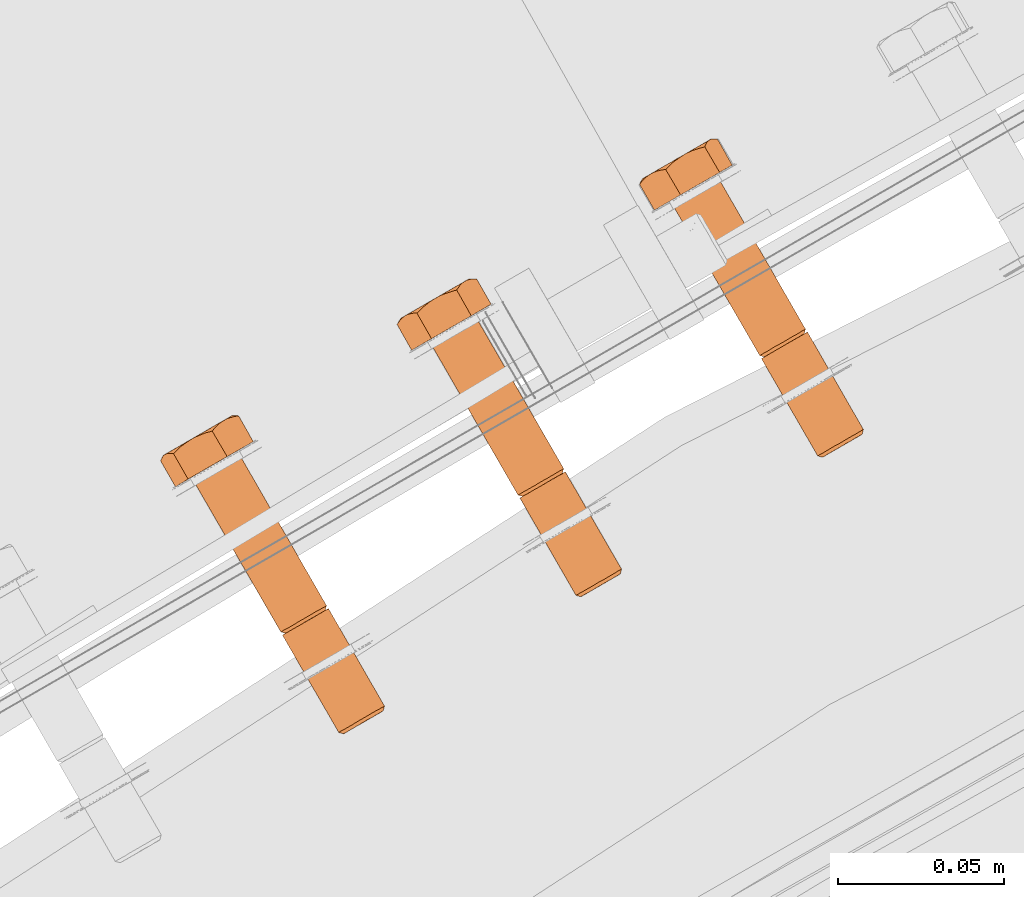
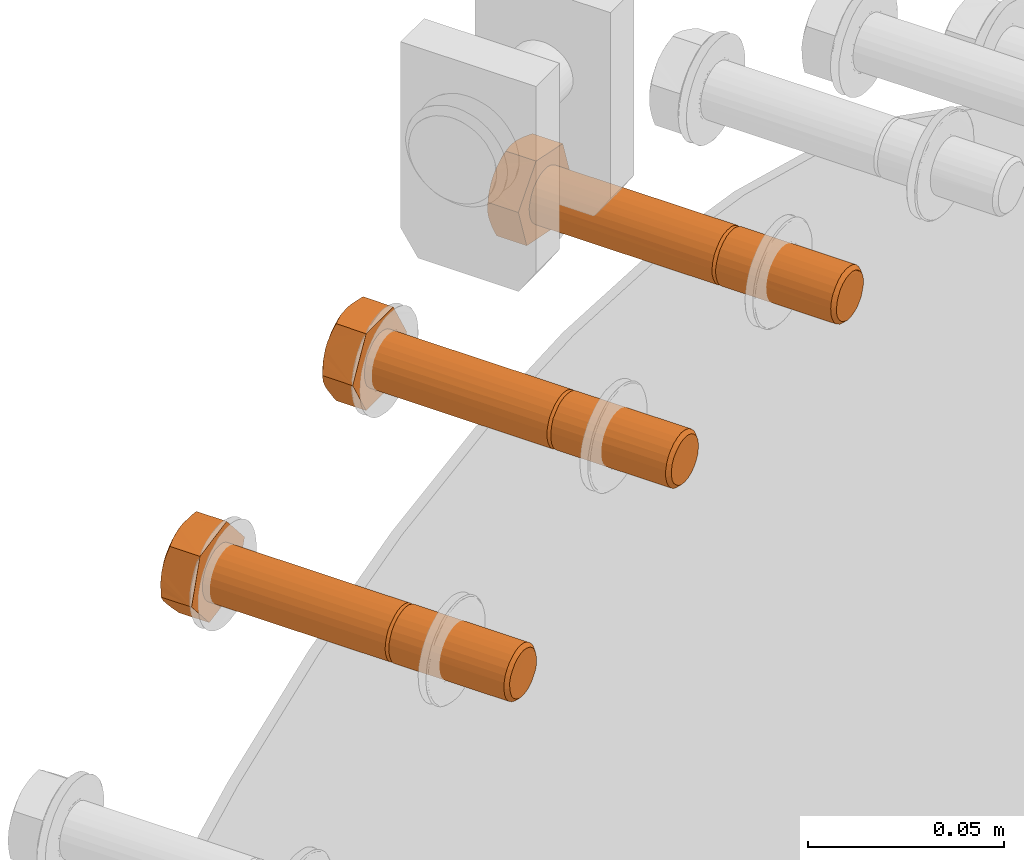
# One storey, part 73 of 126: 3 proxies.
"""IFC2X3 building model written with IfcOpenShell, lengths in millimetres."""

from ifc_helpers import new_model, si_unit, origin, origin_with_axes, place, context, project, spatial, faceted_brep, material, element, save


model = new_model("IFC2X3")

# Units and contexts
context_of_model_1 = context(None, 3, precision=0.1, world=origin())
context_of_model_2 = context(None, 3, precision=0.1, world=origin())
ifc_project = project(units=[si_unit("LENGTHUNIT", "METRE", prefix="MILLI"), si_unit("AREAUNIT", "SQUARE_METRE", prefix="CENTI"), si_unit("VOLUMEUNIT", "CUBIC_METRE", prefix="CENTI"), si_unit("MASSUNIT", "GRAM", prefix="KILO")], contexts=[context_of_model_1, context_of_model_2])

# Site, building, storey
site_placement = place(None, origin_with_axes())
site = spatial("IfcSite", under=ifc_project, at=site_placement, CompositionType="ELEMENT")
building_placement = place(site_placement, origin_with_axes())
building = spatial("IfcBuilding", under=site, at=building_placement, CompositionType="ELEMENT")
storey_placement = place(building_placement, origin_with_axes())
storey = spatial("IfcBuildingStorey", under=building, at=storey_placement, CompositionType="ELEMENT")

# Proxies
ifc_material = material(Name="STAHL")
proxy_1_placement = place(storey_placement, origin_with_axes())
element("IfcBuildingElementProxy", 1, at=proxy_1_placement, inside=storey, material=ifc_material, Name="profile", context=context_of_model_2, shape_type="Brep", body=[
    faceted_brep([(3921.3, 14829.2, 1315.5), (3919.7, 14828.3, 1315.3), (3920.4, 14827.4, 1314.3), (3921.8, 14828.3, 1314.4), (3923.0, 14830.2, 1315.2), (3923.2, 14829.1, 1314.1), (3924.5, 14831.1, 1314.4), (3924.6, 14829.8, 1313.5), (3925.8, 14831.8, 1313.2), (3925.7, 14830.5, 1312.5), (3926.9, 14832.4, 1311.7), (3926.6, 14831.0, 1311.2), (3927.6, 14832.8, 1310.0), (3927.2, 14831.4, 1309.6), (3927.9, 14833.0, 1308.1), (3927.5, 14831.5, 1308.0), (3927.8, 14833.0, 1306.2), (3927.5, 14831.5, 1306.3), (3927.4, 14832.7, 1304.3), (3927.1, 14831.3, 1304.7), (3926.5, 14832.2, 1302.6), (3926.3, 14830.9, 1303.3), (3925.4, 14831.5, 1301.3), (3925.3, 14830.3, 1302.1), (3923.9, 14830.7, 1300.2), (3924.1, 14829.6, 1301.2), (3922.4, 14829.8, 1299.6), (3922.7, 14828.8, 1300.7), (3904.3, 14858.6, 1314.4), (3903.8, 14859.5, 1315.5), (3902.2, 14858.6, 1315.3), (3902.9, 14857.7, 1314.3), (3905.7, 14859.4, 1314.1), (3905.5, 14860.5, 1315.2), (3907.1, 14860.2, 1313.5), (3907.0, 14861.4, 1314.4), (3908.2, 14860.8, 1312.5), (3908.3, 14862.1, 1313.2), (3909.1, 14861.3, 1311.2), (3909.4, 14862.7, 1311.7), (3909.7, 14861.7, 1309.6), (3910.1, 14863.1, 1310.0), (3910.0, 14861.9, 1308.0), (3910.4, 14863.3, 1308.1), (3910.0, 14861.8, 1306.3), (3910.3, 14863.3, 1306.2), (3909.6, 14861.6, 1304.7), (3909.9, 14863.0, 1304.3), (3908.8, 14861.2, 1303.3), (3909.0, 14862.5, 1302.6), (3907.8, 14860.6, 1302.1), (3907.9, 14861.9, 1301.3), (3906.6, 14859.9, 1301.2), (3906.4, 14861.0, 1300.2), (3905.2, 14859.1, 1300.7), (3904.9, 14860.1, 1299.6), (3902.7, 14857.6, 1315.3), (3901.1, 14856.7, 1314.7), (3918.1, 14827.3, 1314.7), (3920.7, 14828.9, 1299.5), (3903.7, 14858.2, 1299.5), (3905.4, 14859.2, 1299.6), (3919.0, 14827.9, 1299.8), (3902.1, 14857.3, 1299.8), (3917.5, 14827.0, 1300.6), (3900.6, 14856.4, 1300.6), (3916.2, 14826.2, 1301.7), (3899.2, 14855.6, 1301.7), (3915.1, 14825.6, 1303.2), (3898.2, 14855.0, 1303.2), (3914.4, 14825.2, 1305.0), (3897.5, 14854.6, 1305.0), (3914.1, 14825.0, 1306.9), (3897.1, 14854.4, 1306.9), (3914.2, 14825.1, 1308.8), (3897.2, 14854.5, 1308.8), (3914.7, 14825.4, 1310.7), (3897.7, 14854.7, 1310.7), (3915.5, 14825.8, 1312.3), (3898.5, 14855.2, 1312.3), (3916.7, 14826.5, 1313.7), (3899.7, 14855.9, 1313.7), (3876.9, 14906.2, 1315.5), (3875.2, 14905.3, 1315.3), (3878.5, 14907.2, 1315.2), (3880.0, 14908.1, 1314.4), (3881.4, 14908.8, 1313.2), (3882.4, 14909.4, 1311.7), (3883.1, 14909.8, 1310.0), (3883.5, 14910.0, 1308.1), (3883.4, 14910.0, 1306.2), (3882.9, 14909.7, 1304.3), (3882.1, 14909.2, 1302.6), (3880.9, 14908.6, 1301.3), (3879.5, 14907.7, 1300.2), (3877.9, 14906.8, 1299.6), (3900.6, 14857.6, 1314.7), (3873.6, 14904.3, 1314.7), (3872.2, 14903.5, 1313.7), (3899.2, 14856.8, 1313.7), (3903.2, 14859.2, 1299.5), (3876.2, 14905.9, 1299.5), (3901.5, 14858.2, 1299.8), (3874.6, 14904.9, 1299.8), (3900.0, 14857.3, 1300.6), (3873.1, 14904.0, 1300.6), (3898.7, 14856.6, 1301.7), (3871.7, 14903.3, 1301.7), (3897.6, 14856.0, 1303.2), (3870.7, 14902.6, 1303.2), (3896.9, 14855.5, 1305.0), (3870.0, 14902.2, 1305.0), (3896.6, 14855.4, 1306.9), (3869.6, 14902.1, 1306.9), (3896.7, 14855.4, 1308.8), (3869.7, 14902.1, 1308.8), (3897.2, 14855.7, 1310.7), (3870.2, 14902.4, 1310.7), (3898.0, 14856.2, 1312.3), (3871.0, 14902.9, 1312.3), (3864.8, 14899.2, 1304.8), (3872.7, 14903.8, 1294.4), (3884.5, 14910.6, 1297.1), (3888.3, 14912.8, 1310.2), (3880.4, 14908.3, 1320.6), (3868.6, 14901.5, 1317.9), (3860.3, 14907.0, 1304.8), (3861.2, 14908.1, 1303.3), (3862.1, 14909.0, 1301.8), (3862.9, 14909.6, 1300.7), (3863.7, 14910.2, 1299.6), (3864.9, 14910.7, 1298.2), (3866.1, 14911.1, 1296.7), (3867.1, 14911.4, 1295.6), (3868.2, 14911.5, 1294.4), (3865.0, 14910.9, 1298.1), (3866.6, 14911.8, 1297.0), (3868.2, 14912.8, 1296.1), (3870.0, 14913.8, 1295.6), (3871.8, 14914.8, 1295.5), (3872.3, 14915.1, 1295.4), (3871.1, 14914.2, 1295.1), (3869.7, 14912.9, 1294.7), (3873.6, 14915.9, 1295.7), (3860.6, 14907.6, 1306.3), (3860.8, 14908.1, 1307.8), (3861.2, 14908.6, 1309.6), (3861.7, 14909.0, 1311.3), (3861.3, 14908.8, 1309.3), (3861.2, 14908.7, 1307.2), (3861.4, 14908.8, 1305.1), (3861.9, 14909.1, 1303.1), (3862.7, 14909.6, 1301.3), (3864.2, 14909.2, 1317.9), (3865.3, 14910.3, 1318.2), (3866.5, 14911.4, 1318.5), (3868.0, 14912.5, 1318.9), (3869.5, 14913.5, 1319.3), (3867.8, 14912.5, 1318.7), (3866.2, 14911.6, 1317.7), (3864.7, 14910.7, 1316.5), (3863.4, 14910.0, 1315.0), (3862.4, 14909.4, 1313.3), (3862.7, 14909.3, 1314.2), (3863.4, 14909.3, 1316.0), (3862.2, 14909.2, 1312.8), (3875.2, 14916.7, 1296.1), (3877.0, 14917.4, 1296.5), (3878.4, 14917.9, 1296.8), (3880.0, 14918.3, 1297.1), (3880.3, 14919.1, 1299.0), (3880.7, 14919.7, 1300.8), (3881.0, 14920.1, 1302.2), (3881.4, 14920.4, 1303.6), (3882.0, 14920.6, 1305.4), (3882.6, 14920.7, 1307.2), (3883.2, 14920.7, 1308.7), (3883.9, 14920.6, 1310.2), (3870.8, 14914.2, 1319.6), (3872.2, 14914.8, 1319.8), (3874.0, 14915.5, 1320.2), (3875.9, 14916.0, 1320.6), (3876.6, 14916.9, 1319.4), (3877.4, 14917.7, 1318.2), (3878.3, 14918.5, 1316.8), (3879.4, 14919.2, 1315.4), (3878.1, 14918.5, 1316.8), (3876.5, 14917.6, 1318.0), (3874.9, 14916.6, 1318.8), (3873.1, 14915.6, 1319.3), (3871.3, 14914.6, 1319.5), (3880.3, 14919.7, 1314.3), (3881.2, 14920.0, 1313.1), (3882.5, 14920.4, 1311.7), (3881.8, 14920.6, 1305.7), (3881.9, 14920.7, 1307.7), (3881.7, 14920.6, 1309.8), (3881.2, 14920.3, 1311.8), (3880.4, 14919.8, 1313.7), (3875.3, 14916.9, 1296.3), (3876.9, 14917.8, 1297.2), (3878.4, 14918.7, 1298.5), (3879.7, 14919.4, 1300.0), (3880.7, 14920.0, 1301.7), (3904.4, 14858.6, 1315.5), (3901.5, 14856.9, 1313.8), (3900.3, 14856.2, 1312.9), (3899.3, 14855.7, 1311.7), (3898.5, 14855.2, 1310.2), (3898.1, 14855.0, 1308.6), (3898.1, 14855.0, 1307.0), (3898.4, 14855.1, 1305.3), (3899.0, 14855.5, 1303.8), (3899.9, 14856.0, 1302.5), (3901.0, 14856.7, 1301.5), (3902.4, 14857.4, 1300.8), (3903.8, 14858.3, 1300.6), (3906.0, 14859.5, 1315.2), (3907.5, 14860.4, 1314.4), (3908.9, 14861.2, 1313.2), (3909.9, 14861.8, 1311.7), (3910.6, 14862.2, 1310.0), (3911.0, 14862.4, 1308.1), (3910.9, 14862.4, 1306.2), (3910.4, 14862.1, 1304.3), (3909.6, 14861.6, 1302.6), (3908.4, 14860.9, 1301.3), (3907.0, 14860.1, 1300.2), (3915.6, 14824.6, 1307.0), (3915.9, 14824.8, 1305.3), (3916.5, 14825.2, 1303.8), (3917.4, 14825.7, 1302.5), (3918.5, 14826.4, 1301.5), (3919.9, 14827.1, 1300.8), (3921.3, 14827.9, 1300.6), (3919.0, 14826.6, 1313.8), (3917.8, 14825.9, 1312.9), (3916.8, 14825.3, 1311.7), (3916.0, 14824.9, 1310.2), (3915.6, 14824.7, 1308.6)], [[[0, 1, 2, 3]], [[4, 0, 3, 5]], [[6, 4, 5, 7]], [[8, 6, 7, 9]], [[10, 8, 9, 11]], [[12, 10, 11, 13]], [[14, 12, 13, 15]], [[16, 14, 15, 17]], [[18, 16, 17, 19]], [[20, 18, 19, 21]], [[22, 20, 21, 23]], [[24, 22, 23, 25]], [[26, 24, 25, 27]], [[28, 29, 30, 31]], [[32, 33, 29, 28]], [[34, 35, 33, 32]], [[36, 37, 35, 34]], [[38, 39, 37, 36]], [[40, 41, 39, 38]], [[42, 43, 41, 40]], [[44, 45, 43, 42]], [[46, 47, 45, 44]], [[48, 49, 47, 46]], [[50, 51, 49, 48]], [[52, 53, 51, 50]], [[54, 55, 53, 52]], [[1, 56, 57, 58]], [[59, 60, 61, 26]], [[62, 63, 60, 59]], [[64, 65, 63, 62]], [[66, 67, 65, 64]], [[68, 69, 67, 66]], [[70, 71, 69, 68]], [[72, 73, 71, 70]], [[74, 75, 73, 72]], [[76, 77, 75, 74]], [[78, 79, 77, 76]], [[80, 81, 79, 78]], [[58, 57, 81, 80]], [[30, 29, 82, 83]], [[29, 33, 84, 82]], [[33, 35, 85, 84]], [[35, 37, 86, 85]], [[37, 39, 87, 86]], [[39, 41, 88, 87]], [[41, 43, 89, 88]], [[43, 45, 90, 89]], [[45, 47, 91, 90]], [[47, 49, 92, 91]], [[49, 51, 93, 92]], [[51, 53, 94, 93]], [[53, 55, 95, 94]], [[96, 97, 98, 99]], [[30, 83, 97, 96]], [[55, 100, 101, 95]], [[102, 103, 101, 100]], [[104, 105, 103, 102]], [[106, 107, 105, 104]], [[108, 109, 107, 106]], [[110, 111, 109, 108]], [[112, 113, 111, 110]], [[114, 115, 113, 112]], [[116, 117, 115, 114]], [[118, 119, 117, 116]], [[99, 98, 119, 118]], [[120, 121, 122, 123, 124, 86, 87, 88, 89, 90, 91, 92, 93, 94, 95, 101, 103, 105, 107, 109, 111, 113, 115, 117, 119, 98, 97, 83, 82, 84, 85, 86, 124, 125]], [[120, 126, 127, 128, 129, 130, 131, 132, 133, 134, 121]], [[130, 135, 136, 137, 138, 139, 140, 141, 142, 134, 133, 132, 131]], [[143, 140, 139]], [[126, 144, 145, 146, 147, 148, 149, 150, 151, 152, 129, 128, 127]], [[130, 129, 152]], [[153, 154, 155, 156, 157, 158, 159, 160, 161, 162, 163, 164]], [[165, 163, 162]], [[147, 165, 162]], [[121, 134, 142, 141, 140, 143, 166, 167, 168, 169, 122]], [[122, 169, 170, 171, 172, 173, 174, 175, 176, 177, 123]], [[178, 179, 180, 181, 182, 183, 184, 185, 186, 187, 188, 189, 190]], [[157, 178, 190]], [[191, 192, 193, 177, 176, 175, 174, 173, 194, 195, 196, 197, 198]], [[185, 191, 198]], [[143, 199, 200, 201, 202, 203, 171, 170, 169, 168, 167, 166]], [[172, 171, 203]], [[173, 172, 203]], [[124, 123, 177, 193, 192, 191, 185, 184, 183, 182, 181]], [[125, 124, 181, 180, 179, 178, 157, 156, 155, 154, 153]], [[120, 125, 153, 164, 163, 165, 147, 146, 145, 144, 126]], [[149, 148, 147, 162, 161, 160, 159, 158, 157, 190, 189, 188, 187, 186, 185, 198, 197, 196, 195, 194, 173, 203, 202, 201, 200, 199, 143, 139, 138, 137, 136, 135, 130, 152, 151, 150]], [[73, 75, 77, 79, 81, 57, 56, 204, 28, 31, 205, 206, 207, 208, 209, 210, 211, 212, 213, 214, 215, 216, 54, 52, 50, 48, 46, 44, 42, 40, 38, 36, 34, 32, 28, 204, 217, 218, 219, 220, 221, 222, 223, 224, 225, 226, 227, 61, 60, 63, 65, 67, 69, 71]], [[100, 55, 54, 216]], [[102, 100, 216, 215]], [[104, 102, 215, 214]], [[106, 104, 214, 213]], [[108, 106, 213, 212]], [[110, 108, 212, 211]], [[112, 110, 211, 210]], [[114, 112, 210, 209]], [[116, 114, 209, 208]], [[118, 116, 208, 207]], [[99, 118, 207, 206]], [[96, 99, 206, 205]], [[31, 30, 96, 205]], [[0, 204, 56, 1]], [[0, 4, 217, 204]], [[4, 6, 218, 217]], [[6, 8, 219, 218]], [[8, 10, 220, 219]], [[10, 12, 221, 220]], [[12, 14, 222, 221]], [[14, 16, 223, 222]], [[16, 18, 224, 223]], [[18, 20, 225, 224]], [[20, 22, 226, 225]], [[22, 24, 227, 226]], [[24, 26, 61, 227]], [[228, 229, 230, 231, 232, 233, 234, 27, 25, 23, 21, 19, 17, 15, 13, 11, 9, 7, 5, 3, 2, 235, 236, 237, 238, 239]], [[234, 59, 26, 27]], [[233, 62, 59, 234]], [[232, 64, 62, 233]], [[231, 66, 64, 232]], [[230, 68, 66, 231]], [[229, 70, 68, 230]], [[228, 72, 70, 229]], [[239, 74, 72, 228]], [[238, 76, 74, 239]], [[237, 78, 76, 238]], [[236, 80, 78, 237]], [[235, 58, 80, 236]], [[2, 1, 58, 235]]]),
])
proxy_2_placement = place(storey_placement, origin_with_axes())
element("IfcBuildingElementProxy", 2, at=proxy_2_placement, inside=storey, material=ifc_material, Name="profile", context=context_of_model_2, shape_type="Brep", body=[
    faceted_brep([(3994.6, 14870.3, 1330.6), (3994.3, 14871.3, 1331.7), (3992.6, 14870.4, 1331.9), (3993.1, 14869.4, 1330.8), (3995.9, 14871.0, 1330.1), (3995.8, 14872.2, 1331.0), (3997.1, 14871.7, 1329.1), (3997.2, 14873.0, 1329.9), (3998.1, 14872.3, 1327.9), (3998.3, 14873.7, 1328.5), (3998.8, 14872.7, 1326.4), (3999.1, 14874.1, 1326.8), (3999.1, 14872.9, 1324.8), (3999.5, 14874.3, 1324.9), (3999.1, 14872.9, 1323.1), (3999.5, 14874.3, 1323.0), (3998.8, 14872.7, 1321.5), (3999.1, 14874.1, 1321.1), (3998.1, 14872.3, 1320.0), (3998.3, 14873.7, 1319.4), (3997.1, 14871.7, 1318.8), (3997.2, 14873.0, 1317.9), (3995.9, 14871.0, 1317.8), (3995.8, 14872.2, 1316.8), (3994.6, 14870.3, 1317.2), (3994.3, 14871.3, 1316.2), (3993.1, 14869.4, 1317.0), (3992.6, 14870.4, 1315.9), (3977.1, 14900.6, 1330.6), (3976.8, 14901.6, 1331.7), (3975.1, 14900.7, 1331.9), (3975.6, 14899.7, 1330.8), (3978.4, 14901.4, 1330.1), (3978.3, 14902.5, 1331.0), (3979.6, 14902.0, 1329.1), (3979.7, 14903.3, 1329.9), (3980.6, 14902.6, 1327.9), (3980.8, 14904.0, 1328.5), (3981.3, 14903.0, 1326.4), (3981.6, 14904.4, 1326.8), (3981.6, 14903.2, 1324.8), (3982.0, 14904.7, 1324.9), (3981.6, 14903.2, 1323.1), (3982.0, 14904.7, 1323.0), (3981.3, 14903.0, 1321.5), (3981.6, 14904.4, 1321.1), (3980.6, 14902.6, 1320.0), (3980.8, 14904.0, 1319.4), (3979.6, 14902.0, 1318.8), (3979.7, 14903.3, 1317.9), (3978.4, 14901.4, 1317.8), (3978.3, 14902.5, 1316.8), (3977.1, 14900.6, 1317.2), (3976.8, 14901.6, 1316.2), (3975.6, 14899.7, 1317.0), (3975.1, 14900.7, 1315.9), (3975.6, 14899.7, 1331.9), (3974.0, 14898.8, 1331.7), (3991.0, 14869.4, 1331.7), (3991.0, 14869.4, 1316.2), (3974.0, 14898.8, 1316.2), (3975.6, 14899.7, 1315.9), (3989.4, 14868.5, 1316.8), (3972.4, 14897.9, 1316.8), (3988.0, 14867.7, 1317.9), (3971.1, 14897.1, 1317.9), (3986.9, 14867.1, 1319.4), (3969.9, 14896.5, 1319.4), (3986.1, 14866.6, 1321.1), (3969.2, 14896.0, 1321.1), (3985.7, 14866.4, 1323.0), (3968.8, 14895.8, 1323.0), (3985.7, 14866.4, 1324.9), (3968.8, 14895.8, 1324.9), (3986.1, 14866.6, 1326.8), (3969.2, 14896.0, 1326.8), (3986.9, 14867.1, 1328.5), (3969.9, 14896.5, 1328.5), (3988.0, 14867.7, 1329.9), (3971.1, 14897.1, 1329.9), (3989.4, 14868.5, 1331.0), (3972.4, 14897.9, 1331.0), (3949.8, 14948.3, 1331.7), (3948.1, 14947.4, 1331.9), (3951.4, 14949.2, 1331.0), (3952.7, 14950.0, 1329.9), (3953.9, 14950.7, 1328.5), (3954.6, 14951.1, 1326.8), (3955.0, 14951.3, 1324.9), (3955.0, 14951.3, 1323.0), (3954.6, 14951.1, 1321.1), (3953.9, 14950.7, 1319.4), (3952.7, 14950.0, 1317.9), (3951.4, 14949.2, 1316.8), (3949.8, 14948.3, 1316.2), (3948.1, 14947.4, 1315.9), (3973.5, 14899.7, 1316.2), (3946.5, 14946.4, 1316.2), (3971.9, 14898.8, 1316.8), (3944.9, 14945.5, 1316.8), (3970.5, 14898.0, 1317.9), (3943.6, 14944.7, 1317.9), (3969.4, 14897.4, 1319.4), (3942.4, 14944.1, 1319.4), (3968.6, 14896.9, 1321.1), (3941.7, 14943.6, 1321.1), (3968.2, 14896.7, 1323.0), (3941.3, 14943.4, 1323.0), (3968.2, 14896.7, 1324.9), (3941.3, 14943.4, 1324.9), (3968.6, 14896.9, 1326.8), (3941.7, 14943.6, 1326.8), (3969.4, 14897.4, 1328.5), (3942.4, 14944.1, 1328.5), (3970.5, 14898.0, 1329.9), (3943.6, 14944.7, 1329.9), (3971.9, 14898.8, 1331.0), (3944.9, 14945.5, 1331.0), (3973.5, 14899.7, 1331.7), (3946.5, 14946.4, 1331.7), (3936.1, 14940.4, 1323.9), (3942.1, 14943.9, 1311.9), (3954.1, 14950.8, 1311.9), (3960.1, 14954.3, 1323.9), (3954.1, 14950.8, 1335.9), (3942.1, 14943.9, 1335.9), (3931.7, 14948.2, 1323.9), (3932.3, 14949.1, 1322.2), (3932.9, 14949.9, 1320.5), (3933.5, 14950.4, 1319.2), (3934.1, 14950.8, 1317.9), (3935.0, 14951.2, 1316.3), (3936.0, 14951.5, 1314.7), (3936.8, 14951.6, 1313.3), (3937.7, 14951.6, 1311.9), (3935.2, 14951.4, 1316.2), (3936.5, 14952.2, 1314.7), (3938.0, 14953.0, 1313.5), (3939.6, 14954.0, 1312.7), (3941.3, 14955.0, 1312.1), (3941.9, 14955.2, 1311.9), (3940.6, 14954.3, 1311.9), (3939.1, 14953.1, 1311.9), (3943.1, 14956.0, 1311.9), (3932.2, 14948.9, 1325.3), (3932.7, 14949.6, 1326.7), (3933.4, 14950.3, 1328.3), (3934.1, 14950.8, 1329.9), (3933.4, 14950.4, 1328.0), (3932.9, 14950.1, 1326.0), (3932.8, 14950.0, 1323.9), (3932.9, 14950.1, 1321.8), (3933.4, 14950.4, 1319.8), (3934.8, 14951.2, 1331.2), (3935.6, 14951.4, 1332.5), (3936.6, 14951.6, 1334.2), (3937.7, 14951.6, 1335.9), (3938.9, 14952.8, 1335.9), (3940.0, 14953.8, 1335.9), (3941.5, 14955.0, 1335.9), (3943.1, 14956.0, 1335.9), (3941.3, 14955.0, 1335.7), (3939.6, 14954.0, 1335.2), (3938.0, 14953.0, 1334.3), (3936.5, 14952.2, 1333.1), (3935.2, 14951.4, 1331.6), (3944.8, 14956.9, 1311.9), (3946.6, 14957.6, 1311.9), (3948.1, 14958.1, 1311.9), (3949.7, 14958.6, 1311.9), (3950.3, 14959.5, 1313.7), (3950.9, 14960.3, 1315.3), (3951.5, 14960.8, 1316.6), (3952.1, 14961.2, 1317.9), (3953.0, 14961.6, 1319.6), (3954.0, 14961.9, 1321.2), (3954.8, 14962.0, 1322.5), (3955.7, 14962.0, 1323.9), (3945.0, 14957.1, 1335.7), (3945.9, 14957.4, 1335.9), (3947.7, 14958.0, 1335.9), (3949.7, 14958.6, 1335.9), (3950.2, 14959.3, 1334.5), (3950.7, 14960.0, 1333.2), (3951.4, 14960.7, 1331.6), (3952.1, 14961.2, 1329.9), (3951.1, 14960.6, 1331.6), (3949.8, 14959.9, 1333.1), (3948.3, 14959.0, 1334.3), (3946.7, 14958.1, 1335.2), (3944.5, 14956.8, 1335.9), (3952.9, 14961.7, 1319.8), (3953.4, 14961.9, 1321.8), (3953.5, 14962.0, 1323.9), (3953.4, 14961.9, 1326.0), (3952.9, 14961.7, 1328.0), (3952.8, 14961.6, 1328.6), (3953.6, 14961.8, 1327.3), (3954.6, 14962.0, 1325.7), (3945.0, 14957.1, 1312.1), (3946.7, 14958.1, 1312.7), (3948.3, 14959.0, 1313.5), (3949.8, 14959.9, 1314.7), (3951.1, 14960.6, 1316.2), (3977.3, 14900.7, 1331.7), (3978.9, 14901.6, 1331.0), (3980.2, 14902.4, 1329.9), (3981.4, 14903.0, 1328.5), (3982.1, 14903.5, 1326.8), (3982.5, 14903.7, 1324.9), (3982.5, 14903.7, 1323.0), (3982.1, 14903.5, 1321.1), (3981.4, 14903.0, 1319.4), (3980.2, 14902.4, 1317.9), (3978.9, 14901.6, 1316.8), (3977.3, 14900.7, 1316.2), (3969.7, 14896.3, 1323.1), (3970.0, 14896.5, 1321.5), (3970.7, 14896.9, 1320.0), (3971.7, 14897.5, 1318.8), (3972.9, 14898.1, 1317.8), (3974.2, 14898.9, 1317.2), (3974.2, 14898.9, 1330.6), (3972.9, 14898.1, 1330.1), (3971.7, 14897.5, 1329.1), (3970.7, 14896.9, 1327.9), (3970.0, 14896.5, 1326.4), (3969.7, 14896.3, 1324.8), (3987.2, 14866.0, 1324.8), (3987.2, 14866.0, 1323.1), (3987.5, 14866.2, 1321.5), (3988.2, 14866.6, 1320.0), (3989.2, 14867.1, 1318.8), (3990.4, 14867.8, 1317.8), (3991.7, 14868.6, 1317.2), (3991.7, 14868.6, 1330.6), (3990.4, 14867.8, 1330.1), (3989.2, 14867.1, 1329.1), (3988.2, 14866.6, 1327.9), (3987.5, 14866.2, 1326.4)], [[[0, 1, 2, 3]], [[4, 5, 1, 0]], [[6, 7, 5, 4]], [[8, 9, 7, 6]], [[10, 11, 9, 8]], [[12, 13, 11, 10]], [[14, 15, 13, 12]], [[16, 17, 15, 14]], [[18, 19, 17, 16]], [[20, 21, 19, 18]], [[22, 23, 21, 20]], [[24, 25, 23, 22]], [[26, 27, 25, 24]], [[28, 29, 30, 31]], [[32, 33, 29, 28]], [[34, 35, 33, 32]], [[36, 37, 35, 34]], [[38, 39, 37, 36]], [[40, 41, 39, 38]], [[42, 43, 41, 40]], [[44, 45, 43, 42]], [[46, 47, 45, 44]], [[48, 49, 47, 46]], [[50, 51, 49, 48]], [[52, 53, 51, 50]], [[54, 55, 53, 52]], [[2, 56, 57, 58]], [[59, 60, 61, 27]], [[62, 63, 60, 59]], [[64, 65, 63, 62]], [[66, 67, 65, 64]], [[68, 69, 67, 66]], [[70, 71, 69, 68]], [[72, 73, 71, 70]], [[74, 75, 73, 72]], [[76, 77, 75, 74]], [[78, 79, 77, 76]], [[80, 81, 79, 78]], [[58, 57, 81, 80]], [[30, 29, 82, 83]], [[29, 33, 84, 82]], [[33, 35, 85, 84]], [[35, 37, 86, 85]], [[37, 39, 87, 86]], [[39, 41, 88, 87]], [[41, 43, 89, 88]], [[43, 45, 90, 89]], [[45, 47, 91, 90]], [[47, 49, 92, 91]], [[49, 51, 93, 92]], [[51, 53, 94, 93]], [[53, 55, 95, 94]], [[96, 97, 95, 55]], [[96, 98, 99, 97]], [[98, 100, 101, 99]], [[100, 102, 103, 101]], [[102, 104, 105, 103]], [[104, 106, 107, 105]], [[106, 108, 109, 107]], [[108, 110, 111, 109]], [[110, 112, 113, 111]], [[112, 114, 115, 113]], [[114, 116, 117, 115]], [[116, 118, 119, 117]], [[118, 30, 83, 119]], [[120, 121, 122, 123, 124, 86, 87, 88, 89, 90, 91, 92, 93, 94, 95, 97, 99, 101, 103, 105, 107, 109, 111, 113, 115, 117, 119, 83, 82, 84, 85, 86, 124, 125]], [[120, 126, 127, 128, 129, 130, 131, 132, 133, 134, 121]], [[130, 135, 136, 137, 138, 139, 140, 141, 142, 134, 133, 132, 131]], [[143, 140, 139]], [[126, 144, 145, 146, 147, 148, 149, 150, 151, 152, 129, 128, 127]], [[130, 129, 152]], [[153, 154, 155, 156, 157, 158, 159, 160, 161, 162, 163, 164, 165]], [[147, 153, 165]], [[121, 134, 142, 141, 140, 143, 166, 167, 168, 169, 122]], [[122, 169, 170, 171, 172, 173, 174, 175, 176, 177, 123]], [[178, 179, 180, 181, 182, 183, 184, 185, 186, 187, 188, 189]], [[190, 179, 178]], [[160, 190, 178]], [[173, 191, 192, 193, 194, 195, 196, 197, 198, 177, 176, 175, 174]], [[185, 196, 195]], [[143, 199, 200, 201, 202, 203, 172, 171, 170, 169, 168, 167, 166]], [[173, 172, 203]], [[124, 123, 177, 198, 197, 196, 185, 184, 183, 182, 181]], [[125, 124, 181, 180, 179, 190, 160, 159, 158, 157, 156]], [[120, 125, 156, 155, 154, 153, 147, 146, 145, 144, 126]], [[150, 149, 148, 147, 165, 164, 163, 162, 161, 160, 178, 189, 188, 187, 186, 185, 195, 194, 193, 192, 191, 173, 203, 202, 201, 200, 199, 143, 139, 138, 137, 136, 135, 130, 152, 151]], [[71, 73, 75, 77, 79, 81, 57, 56, 204, 205, 206, 207, 208, 209, 210, 211, 212, 213, 214, 215, 61, 60, 63, 65, 67, 69, 216, 217, 218, 219, 220, 221, 54, 52, 50, 48, 46, 44, 42, 40, 38, 36, 34, 32, 28, 31, 222, 223, 224, 225, 226, 227, 216, 69]], [[221, 96, 55, 54]], [[220, 98, 96, 221]], [[219, 100, 98, 220]], [[218, 102, 100, 219]], [[217, 104, 102, 218]], [[216, 106, 104, 217]], [[227, 108, 106, 216]], [[226, 110, 108, 227]], [[225, 112, 110, 226]], [[224, 114, 112, 225]], [[223, 116, 114, 224]], [[222, 118, 116, 223]], [[31, 30, 118, 222]], [[2, 1, 204, 56]], [[1, 5, 205, 204]], [[5, 7, 206, 205]], [[7, 9, 207, 206]], [[9, 11, 208, 207]], [[11, 13, 209, 208]], [[13, 15, 210, 209]], [[15, 17, 211, 210]], [[17, 19, 212, 211]], [[19, 21, 213, 212]], [[21, 23, 214, 213]], [[23, 25, 215, 214]], [[25, 27, 61, 215]], [[228, 229, 230, 231, 232, 233, 234, 26, 24, 22, 20, 18, 16, 14, 12, 10, 8, 6, 4, 0, 3, 235, 236, 237, 238, 239]], [[234, 59, 27, 26]], [[233, 62, 59, 234]], [[232, 64, 62, 233]], [[231, 66, 64, 232]], [[230, 68, 66, 231]], [[229, 70, 68, 230]], [[228, 72, 70, 229]], [[239, 74, 72, 228]], [[238, 76, 74, 239]], [[237, 78, 76, 238]], [[236, 80, 78, 237]], [[235, 58, 80, 236]], [[3, 2, 58, 235]]]),
])
proxy_3_placement = place(storey_placement, origin_with_axes())
element("IfcBuildingElementProxy", 3, at=proxy_3_placement, inside=storey, material=ifc_material, Name="profile", context=context_of_model_2, shape_type="Brep", body=[
    faceted_brep([(4068.7, 14913.0, 1330.2), (4068.5, 14914.2, 1331.2), (4067.0, 14913.3, 1331.8), (4067.3, 14912.3, 1330.7), (4069.9, 14913.8, 1329.3), (4070.0, 14915.0, 1330.2), (4070.9, 14914.3, 1328.1), (4071.1, 14915.7, 1328.8), (4071.7, 14914.8, 1326.7), (4072.0, 14916.2, 1327.1), (4072.1, 14915.0, 1325.1), (4072.4, 14916.5, 1325.3), (4072.1, 14915.0, 1323.4), (4072.5, 14916.5, 1323.3), (4071.8, 14914.9, 1321.8), (4072.2, 14916.3, 1321.4), (4071.2, 14914.5, 1320.3), (4071.5, 14915.9, 1319.7), (4070.3, 14914.0, 1319.0), (4070.4, 14915.3, 1318.2), (4069.2, 14913.3, 1318.0), (4069.1, 14914.5, 1317.0), (4067.8, 14912.6, 1317.3), (4067.6, 14913.7, 1316.3), (4066.4, 14911.7, 1317.0), (4065.9, 14912.7, 1315.9), (4065.0, 14910.9, 1317.1), (4064.3, 14911.7, 1316.1), (4051.0, 14944.5, 1331.2), (4049.5, 14943.6, 1331.8), (4049.8, 14942.6, 1330.7), (4051.2, 14943.4, 1330.2), (4052.5, 14945.3, 1330.2), (4052.4, 14944.1, 1329.3), (4053.6, 14946.0, 1328.8), (4053.4, 14944.6, 1328.1), (4054.5, 14946.5, 1327.1), (4054.2, 14945.1, 1326.7), (4054.9, 14946.8, 1325.3), (4054.6, 14945.3, 1325.1), (4055.0, 14946.8, 1323.3), (4054.6, 14945.3, 1323.4), (4054.7, 14946.6, 1321.4), (4054.3, 14945.2, 1321.8), (4054.0, 14946.2, 1319.7), (4053.7, 14944.8, 1320.3), (4052.9, 14945.6, 1318.2), (4052.8, 14944.3, 1319.0), (4051.6, 14944.8, 1317.0), (4051.7, 14943.6, 1318.0), (4050.1, 14944.0, 1316.3), (4050.3, 14942.9, 1317.3), (4048.4, 14943.0, 1315.9), (4048.9, 14942.0, 1317.0), (4046.8, 14942.0, 1316.1), (4047.5, 14941.2, 1317.1), (4062.7, 14910.8, 1316.7), (4045.7, 14940.2, 1316.7), (4047.3, 14941.1, 1316.1), (4061.3, 14910.0, 1317.7), (4044.3, 14939.4, 1317.7), (4060.1, 14909.3, 1319.1), (4043.1, 14938.7, 1319.1), (4059.3, 14908.8, 1320.8), (4042.3, 14938.2, 1320.8), (4058.8, 14908.6, 1322.6), (4041.8, 14937.9, 1322.6), (4058.7, 14908.5, 1324.5), (4041.7, 14937.9, 1324.5), (4059.0, 14908.7, 1326.4), (4042.1, 14938.1, 1326.4), (4059.7, 14909.1, 1328.2), (4042.8, 14938.5, 1328.2), (4060.8, 14909.7, 1329.7), (4043.8, 14939.1, 1329.7), (4062.1, 14910.5, 1330.8), (4045.2, 14939.9, 1330.8), (4063.6, 14911.4, 1331.6), (4046.7, 14940.8, 1331.6), (4065.3, 14912.3, 1331.9), (4048.3, 14941.7, 1331.9), (4050.0, 14942.7, 1331.8), (4021.5, 14989.7, 1315.9), (4023.1, 14990.7, 1316.3), (4019.8, 14988.7, 1316.1), (4024.1, 14991.2, 1331.2), (4022.5, 14990.3, 1331.8), (4025.5, 14992.0, 1330.2), (4026.7, 14992.7, 1328.8), (4027.5, 14993.2, 1327.1), (4028.0, 14993.5, 1325.3), (4028.1, 14993.5, 1323.3), (4027.7, 14993.3, 1321.4), (4027.0, 14992.9, 1319.7), (4026.0, 14992.3, 1318.2), (4024.6, 14991.5, 1317.0), (4045.2, 14941.1, 1316.7), (4018.2, 14987.8, 1316.7), (4043.8, 14940.3, 1317.7), (4016.8, 14987.0, 1317.7), (4042.6, 14939.6, 1319.1), (4015.6, 14986.3, 1319.1), (4041.8, 14939.2, 1320.8), (4014.8, 14985.9, 1320.8), (4041.3, 14938.9, 1322.6), (4014.3, 14985.6, 1322.6), (4041.2, 14938.8, 1324.5), (4014.2, 14985.5, 1324.5), (4041.5, 14939.0, 1326.4), (4014.6, 14985.7, 1326.4), (4042.2, 14939.4, 1328.2), (4015.3, 14986.1, 1328.2), (4043.3, 14940.0, 1329.7), (4016.3, 14986.7, 1329.7), (4044.6, 14940.8, 1330.8), (4017.7, 14987.5, 1330.8), (4046.1, 14941.7, 1331.6), (4019.2, 14988.4, 1331.6), (4047.8, 14942.6, 1331.9), (4020.8, 14989.3, 1331.9), (4009.4, 14982.7, 1326.6), (4013.2, 14985.0, 1313.5), (4025.0, 14991.8, 1310.8), (4032.9, 14996.3, 1321.2), (4029.1, 14994.1, 1334.3), (4017.3, 14987.3, 1337.1), (4004.9, 14990.5, 1326.6), (4005.2, 14991.2, 1324.7), (4005.6, 14991.8, 1322.9), (4005.9, 14992.2, 1321.5), (4006.3, 14992.5, 1320.1), (4006.9, 14992.7, 1318.3), (4007.5, 14992.8, 1316.5), (4008.1, 14992.8, 1315.0), (4008.8, 14992.7, 1313.5), (4007.0, 14992.9, 1318.2), (4008.0, 14993.5, 1316.4), (4009.3, 14994.2, 1314.9), (4010.8, 14995.1, 1313.7), (4012.4, 14996.0, 1312.7), (4012.9, 14996.2, 1312.5), (4011.6, 14995.3, 1312.8), (4010.2, 14994.1, 1313.1), (4014.1, 14997.0, 1312.2), (4005.6, 14991.4, 1327.8), (4006.3, 14992.1, 1329.0), (4007.3, 14993.0, 1330.4), (4008.3, 14993.7, 1331.8), (4007.3, 14993.1, 1330.2), (4006.5, 14992.6, 1328.3), (4006.0, 14992.3, 1326.3), (4005.8, 14992.2, 1324.2), (4005.9, 14992.3, 1322.1), (4009.2, 14994.1, 1333.0), (4010.2, 14994.5, 1334.1), (4011.4, 14994.8, 1335.6), (4012.8, 14995.0, 1337.1), (4014.0, 14996.2, 1336.7), (4015.1, 14997.2, 1336.4), (4016.6, 14998.3, 1336.1), (4018.2, 14999.4, 1335.7), (4016.4, 14998.3, 1335.9), (4014.6, 14997.3, 1335.8), (4012.8, 14996.3, 1335.3), (4011.2, 14995.3, 1334.5), (4009.6, 14994.4, 1333.3), (4015.8, 14997.9, 1311.8), (4017.5, 14998.6, 1311.4), (4019.0, 14999.1, 1311.1), (4020.5, 14999.5, 1310.8), (4021.4, 15000.6, 1312.3), (4022.3, 15001.5, 1313.7), (4023.1, 15002.1, 1314.9), (4024.0, 15002.7, 1316.0), (4025.1, 15003.2, 1317.4), (4026.3, 15003.7, 1318.9), (4027.3, 15003.9, 1320.0), (4028.5, 15004.1, 1321.2), (4019.9, 15000.4, 1335.1), (4020.9, 15000.7, 1335.1), (4022.7, 15001.3, 1334.7), (4024.6, 15001.8, 1334.3), (4024.8, 15002.4, 1332.8), (4025.1, 15003.0, 1331.4), (4025.5, 15003.5, 1329.6), (4026.0, 15003.9, 1327.8), (4025.3, 15003.4, 1329.7), (4024.3, 15002.9, 1331.4), (4023.0, 15002.1, 1333.0), (4021.5, 15001.3, 1334.2), (4019.5, 15000.1, 1335.4), (4025.0, 15003.3, 1317.7), (4025.8, 15003.8, 1319.6), (4026.3, 15004.1, 1321.6), (4026.5, 15004.2, 1323.7), (4026.4, 15004.1, 1325.8), (4026.4, 15004.1, 1326.4), (4026.9, 15004.2, 1324.9), (4027.6, 15004.2, 1323.1), (4015.9, 14998.1, 1311.9), (4017.7, 14999.1, 1312.1), (4019.5, 15000.1, 1312.6), (4021.1, 15001.1, 1313.4), (4022.7, 15001.9, 1314.6), (4051.6, 14943.6, 1331.2), (4048.4, 14941.7, 1330.8), (4047.0, 14940.9, 1330.6), (4045.6, 14940.1, 1329.9), (4044.5, 14939.5, 1328.9), (4043.6, 14939.0, 1327.6), (4043.0, 14938.6, 1326.1), (4042.7, 14938.4, 1324.5), (4042.7, 14938.5, 1322.8), (4043.1, 14938.7, 1321.2), (4043.9, 14939.1, 1319.7), (4044.9, 14939.7, 1318.5), (4046.1, 14940.4, 1317.7), (4053.0, 14944.4, 1330.2), (4054.2, 14945.1, 1328.8), (4055.0, 14945.6, 1327.1), (4055.5, 14945.8, 1325.3), (4055.6, 14945.9, 1323.3), (4055.2, 14945.7, 1321.4), (4054.5, 14945.3, 1319.7), (4053.5, 14944.7, 1318.2), (4052.1, 14943.9, 1317.0), (4050.6, 14943.0, 1316.3), (4049.0, 14942.1, 1315.9), (4060.2, 14908.1, 1324.5), (4060.2, 14908.2, 1322.8), (4060.6, 14908.4, 1321.2), (4061.4, 14908.8, 1319.7), (4062.4, 14909.4, 1318.5), (4063.6, 14910.1, 1317.7), (4065.9, 14911.4, 1330.8), (4064.5, 14910.6, 1330.6), (4063.1, 14909.8, 1329.9), (4062.0, 14909.2, 1328.9), (4061.1, 14908.6, 1327.6), (4060.5, 14908.3, 1326.1)], [[[0, 1, 2, 3]], [[4, 5, 1, 0]], [[6, 7, 5, 4]], [[8, 9, 7, 6]], [[10, 11, 9, 8]], [[12, 13, 11, 10]], [[14, 15, 13, 12]], [[16, 17, 15, 14]], [[18, 19, 17, 16]], [[20, 21, 19, 18]], [[22, 23, 21, 20]], [[24, 25, 23, 22]], [[26, 27, 25, 24]], [[28, 29, 30, 31]], [[32, 28, 31, 33]], [[34, 32, 33, 35]], [[36, 34, 35, 37]], [[38, 36, 37, 39]], [[40, 38, 39, 41]], [[42, 40, 41, 43]], [[44, 42, 43, 45]], [[46, 44, 45, 47]], [[48, 46, 47, 49]], [[50, 48, 49, 51]], [[52, 50, 51, 53]], [[54, 52, 53, 55]], [[27, 56, 57, 58]], [[56, 59, 60, 57]], [[59, 61, 62, 60]], [[61, 63, 64, 62]], [[63, 65, 66, 64]], [[65, 67, 68, 66]], [[67, 69, 70, 68]], [[69, 71, 72, 70]], [[71, 73, 74, 72]], [[73, 75, 76, 74]], [[75, 77, 78, 76]], [[77, 79, 80, 78]], [[79, 2, 81, 80]], [[52, 82, 83, 50]], [[54, 84, 82, 52]], [[29, 28, 85, 86]], [[32, 87, 85, 28]], [[34, 88, 87, 32]], [[36, 89, 88, 34]], [[38, 90, 89, 36]], [[40, 91, 90, 38]], [[42, 92, 91, 40]], [[44, 93, 92, 42]], [[46, 94, 93, 44]], [[48, 95, 94, 46]], [[50, 83, 95, 48]], [[54, 96, 97, 84]], [[96, 98, 99, 97]], [[98, 100, 101, 99]], [[100, 102, 103, 101]], [[102, 104, 105, 103]], [[104, 106, 107, 105]], [[106, 108, 109, 107]], [[108, 110, 111, 109]], [[110, 112, 113, 111]], [[112, 114, 115, 113]], [[114, 116, 117, 115]], [[116, 118, 119, 117]], [[118, 29, 86, 119]], [[120, 121, 122, 123, 124, 89, 90, 91, 92, 93, 94, 95, 83, 82, 84, 97, 99, 101, 103, 105, 107, 109, 111, 113, 115, 117, 119, 86, 85, 87, 88, 89, 124, 125]], [[120, 126, 127, 128, 129, 130, 131, 132, 133, 134, 121]], [[130, 135, 136, 137, 138, 139, 140, 141, 142, 134, 133, 132, 131]], [[143, 140, 139]], [[126, 144, 145, 146, 147, 148, 149, 150, 151, 152, 129, 128, 127]], [[130, 129, 152]], [[153, 154, 155, 156, 157, 158, 159, 160, 161, 162, 163, 164, 165]], [[147, 153, 165]], [[121, 134, 142, 141, 140, 143, 166, 167, 168, 169, 122]], [[122, 169, 170, 171, 172, 173, 174, 175, 176, 177, 123]], [[178, 179, 180, 181, 182, 183, 184, 185, 186, 187, 188, 189]], [[190, 179, 178]], [[160, 190, 178]], [[173, 191, 192, 193, 194, 195, 196, 197, 198, 177, 176, 175, 174]], [[185, 196, 195]], [[143, 199, 200, 201, 202, 203, 172, 171, 170, 169, 168, 167, 166]], [[173, 172, 203]], [[124, 123, 177, 198, 197, 196, 185, 184, 183, 182, 181]], [[125, 124, 181, 180, 179, 190, 160, 159, 158, 157, 156]], [[120, 125, 156, 155, 154, 153, 147, 146, 145, 144, 126]], [[151, 150, 149, 148, 147, 165, 164, 163, 162, 161, 160, 178, 189, 188, 187, 186, 185, 195, 194, 193, 192, 191, 173, 203, 202, 201, 200, 199, 143, 139, 138, 137, 136, 135, 130, 152]], [[68, 70, 72, 74, 76, 78, 80, 81, 204, 31, 30, 205, 206, 207, 208, 209, 210, 211, 212, 213, 214, 215, 216, 55, 53, 51, 49, 47, 45, 43, 41, 39, 37, 35, 33, 31, 204, 217, 218, 219, 220, 221, 222, 223, 224, 225, 226, 227, 58, 57, 60, 62, 64, 66]], [[96, 54, 55, 216]], [[98, 96, 216, 215]], [[100, 98, 215, 214]], [[102, 100, 214, 213]], [[104, 102, 213, 212]], [[106, 104, 212, 211]], [[108, 106, 211, 210]], [[110, 108, 210, 209]], [[112, 110, 209, 208]], [[114, 112, 208, 207]], [[116, 114, 207, 206]], [[118, 116, 206, 205]], [[30, 29, 118, 205]], [[27, 58, 227, 25]], [[1, 204, 81, 2]], [[5, 217, 204, 1]], [[7, 218, 217, 5]], [[9, 219, 218, 7]], [[11, 220, 219, 9]], [[13, 221, 220, 11]], [[15, 222, 221, 13]], [[17, 223, 222, 15]], [[19, 224, 223, 17]], [[21, 225, 224, 19]], [[23, 226, 225, 21]], [[25, 227, 226, 23]], [[228, 229, 230, 231, 232, 233, 26, 24, 22, 20, 18, 16, 14, 12, 10, 8, 6, 4, 0, 3, 234, 235, 236, 237, 238, 239]], [[56, 27, 26, 233]], [[59, 56, 233, 232]], [[61, 59, 232, 231]], [[63, 61, 231, 230]], [[65, 63, 230, 229]], [[67, 65, 229, 228]], [[69, 67, 228, 239]], [[71, 69, 239, 238]], [[73, 71, 238, 237]], [[75, 73, 237, 236]], [[77, 75, 236, 235]], [[79, 77, 235, 234]], [[2, 79, 234, 3]]]),
])

save(model, "model.ifc")
